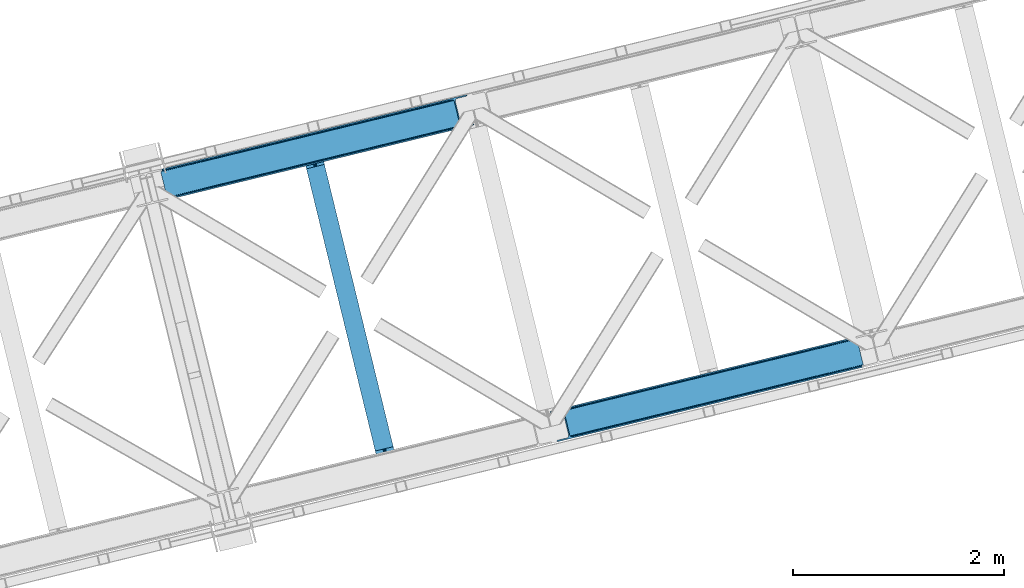
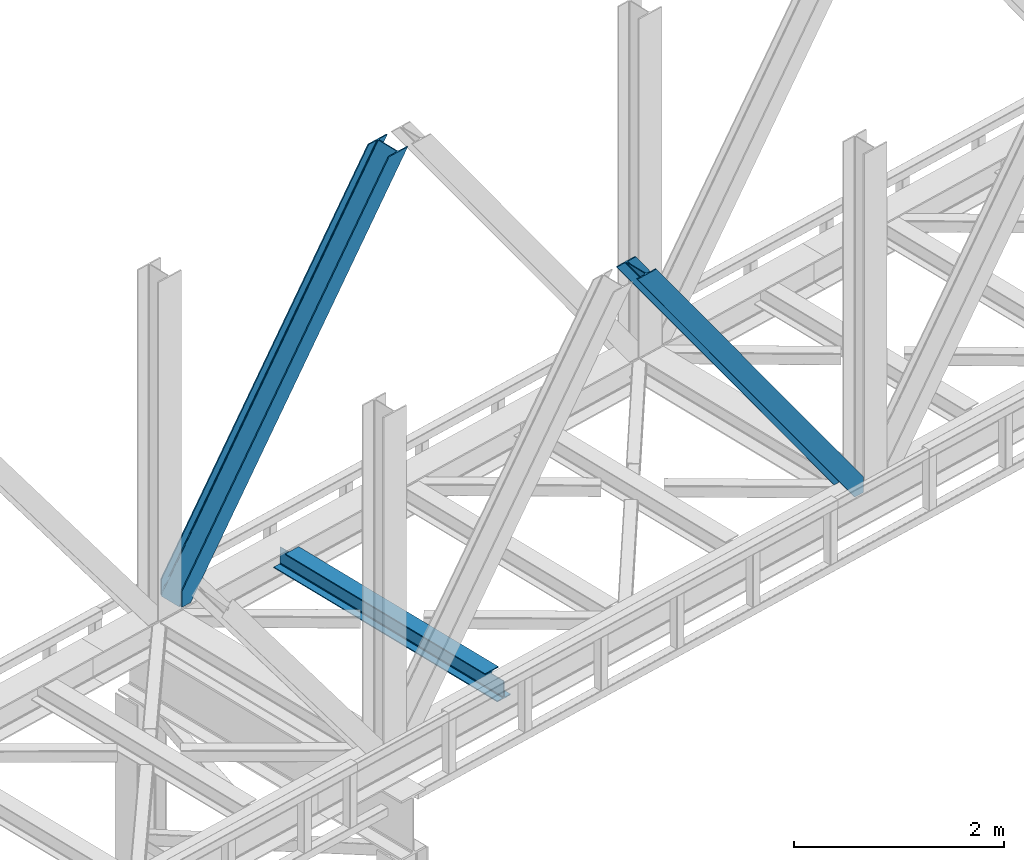
# One storey, part 59 of 92: 2 members, 1 beam.
"""IFC4 building model written with IfcOpenShell, lengths in millimetres."""

from ifc_helpers import new_model, entity, si_unit, converted_unit, derived_unit, direction, frame, origin, place, context, subcontext, project, spatial, triangles, polygons, material, type_object, element, save


model = new_model("IFC4")

# Units and contexts
model_context = context("Model", 3, precision=0.01, world=origin(), true_north=direction((6.12303176911189e-17, 1.0)))
plan_context = context("Plan", 3, precision=0.01, world=origin(), true_north=direction((6.12303176911189e-17, 1.0)))
body_context = subcontext(model_context, "Body", "Model", "MODEL_VIEW")
ifc_project = project(units=[si_unit("LENGTHUNIT", "METRE", prefix="MILLI"), si_unit("AREAUNIT", "SQUARE_METRE"), si_unit("VOLUMEUNIT", "CUBIC_METRE"), converted_unit("PLANEANGLEUNIT", "DEGREE", entity("IfcRatioMeasure", 0.0174532925199433), si_unit("PLANEANGLEUNIT", "RADIAN"), dimensions=[0, 0, 0, 0, 0, 0, 0]), si_unit("MASSUNIT", "GRAM", prefix="KILO"), derived_unit("MASSDENSITYUNIT", [(si_unit("MASSUNIT", "GRAM", prefix="KILO"), 1), (si_unit("LENGTHUNIT", "METRE"), -3)]), derived_unit("MOMENTOFINERTIAUNIT", [(si_unit("LENGTHUNIT", "METRE"), 4)]), si_unit("TIMEUNIT", "SECOND"), si_unit("FREQUENCYUNIT", "HERTZ"), si_unit("THERMODYNAMICTEMPERATUREUNIT", "DEGREE_CELSIUS"), derived_unit("THERMALTRANSMITTANCEUNIT", [(si_unit("MASSUNIT", "GRAM", prefix="KILO"), 1), (si_unit("THERMODYNAMICTEMPERATUREUNIT", "KELVIN"), -1), (si_unit("TIMEUNIT", "SECOND"), -3)]), derived_unit("VOLUMETRICFLOWRATEUNIT", [(si_unit("LENGTHUNIT", "METRE"), 3), (si_unit("TIMEUNIT", "SECOND"), -1)]), derived_unit("MASSFLOWRATEUNIT", [(si_unit("MASSUNIT", "GRAM", prefix="KILO"), 1), (si_unit("TIMEUNIT", "SECOND"), -1)]), derived_unit("ROTATIONALFREQUENCYUNIT", [(si_unit("TIMEUNIT", "SECOND"), -1)]), si_unit("ELECTRICCURRENTUNIT", "AMPERE"), si_unit("ELECTRICVOLTAGEUNIT", "VOLT"), si_unit("POWERUNIT", "WATT"), si_unit("FORCEUNIT", "NEWTON", prefix="KILO"), si_unit("ILLUMINANCEUNIT", "LUX"), si_unit("LUMINOUSFLUXUNIT", "LUMEN"), si_unit("LUMINOUSINTENSITYUNIT", "CANDELA"), derived_unit("USERDEFINED", [(si_unit("MASSUNIT", "GRAM", prefix="KILO"), -1), (si_unit("LENGTHUNIT", "METRE"), -2), (si_unit("TIMEUNIT", "SECOND"), 3), (si_unit("LUMINOUSFLUXUNIT", "LUMEN"), 1)]), derived_unit("LINEARVELOCITYUNIT", [(si_unit("LENGTHUNIT", "METRE"), 1), (si_unit("TIMEUNIT", "SECOND"), -1)]), si_unit("PRESSUREUNIT", "PASCAL"), derived_unit("USERDEFINED", [(si_unit("LENGTHUNIT", "METRE"), -2), (si_unit("MASSUNIT", "GRAM", prefix="KILO"), 1), (si_unit("TIMEUNIT", "SECOND"), -2)]), derived_unit("LINEARFORCEUNIT", [(si_unit("MASSUNIT", "GRAM", prefix="KILO"), 1), (si_unit("LENGTHUNIT", "METRE"), 1), (si_unit("TIMEUNIT", "SECOND"), -2), (si_unit("LENGTHUNIT", "METRE"), -1)]), derived_unit("PLANARFORCEUNIT", [(si_unit("MASSUNIT", "GRAM", prefix="KILO"), 1), (si_unit("LENGTHUNIT", "METRE"), 1), (si_unit("TIMEUNIT", "SECOND"), -2), (si_unit("LENGTHUNIT", "METRE"), -2)])], contexts=[model_context, plan_context])

# Site, building, storey
site_placement = place(None, origin())
site = spatial("IfcSite", under=ifc_project, at=site_placement, CompositionType="ELEMENT")
building_placement = place(site_placement, origin())
building = spatial("IfcBuilding", under=site, at=building_placement, CompositionType="ELEMENT")
storey_placement = place(building_placement, frame((0.0, 0.0, 15900.0)))
storey = spatial("IfcBuildingStorey", under=building, at=storey_placement, Name="05", CompositionType="ELEMENT", Elevation=15900.0)

# Beam
ifc_material = material(Name="Metal painted (White)")
beam_type = type_object("IfcBeamType", PredefinedType="BEAM")
beam_placement = place(storey_placement, frame((-28709.26, 10788.0, 3441.0)))
element("IfcBeam", 1, at=beam_placement, inside=storey, type_object=beam_type, material=ifc_material, ObjectType="Steel Beam", PredefinedType="BEAM", context=body_context, shape_type="Tessellation", body=[
    polygons([(898.853911352528, 41.4445662733125, 11.000000000004), (898.853911352528, 41.4445662733125, 2.16573425859679e-12), (170.021610174761, 3031.3960252037, 2.16573425859679e-12), (170.021610174761, 3031.3960252037, 11.000000000004), (832.788371398907, 25.3403919499678, 11.000000000004), (103.956070221144, 3015.29185088036, 11.000000000004), (826.839621377614, 23.8903211957417, 12.2179274798217), (98.0073201998513, 3013.84178012613, 12.2179274798217), (821.796514621501, 22.6610105689216, 15.6862915010192), (92.964213443734, 3012.61246949931, 15.6862915010192), (818.42681841833, 21.839611468714, 20.8770650821657), (89.5945172405668, 3011.7910703991, 20.8770650821657), (817.243538468644, 21.5511744621227, 27.0000000000047), (88.4112372908809, 3011.50263339251, 27.0000000000047), (81.6103728838888, 3009.84485074158, 27.0000000000047), (81.6103728838888, 3009.84485074158, 203.000000000006), (88.4112372908809, 3011.50263339251, 203.000000000006), (0.0, 2989.95145893039, 2.16573425859679e-12), (0.0, 2989.95145893039, 10.9999999999997), (66.0655399536216, 3006.05563325373, 11.000000000004), (72.014289974914, 3007.50570400796, 12.2179274798217), (77.057396731027, 3008.73501463478, 15.6862915010192), (80.4270929342029, 3009.55641373498, 20.8770650821657), (817.243538468644, 21.5511744621227, 203.000000000006), (810.442674061652, 19.8933918111876, 203.000000000006), (810.442674061652, 19.8933918111919, 27.0000000000047), (809.259394111966, 19.6049548045984, 20.8770650821657), (805.889697908794, 18.7835557043909, 15.6862915010192), (800.846591152681, 17.5542450775685, 12.2179274798217), (794.897841131389, 16.1041743233447, 11.000000000004), (728.832301177767, 0.0, 10.9999999999997), (728.832301177763, 0.0, 2.16573425859679e-12), (777.543778045854, 184.415062601696, 203.069791966819), (125.8889665066, 2857.75452019162, 203.000000000006), (126.111847295751, 2856.8401777572, 203.617301946336), (126.124761540274, 2856.7871977843, 217.000003693143), (777.398574796925, 185.010597404072, 217.000003676718), (777.399445404814, 185.007025963197, 204.00000679514), (770.833476881408, 182.385463974445, 203.006342981529), (770.610629219866, 183.299815969776, 203.617301946336), (770.597714975342, 183.352795942669, 217.000003693143), (119.323901718691, 2855.1293963229, 217.000003676718), (119.323031110802, 2855.13296776378, 204.00000679514), (119.178731521743, 2855.72494066435, 203.076120467494), (119.088102099608, 2856.09673754069, 203.000000000006), (778.58205952096, 185.298194377518, 223.122939328039), (781.951055929627, 186.122464201395, 228.313710402595), (786.993691333646, 187.353708426699, 231.782072735464), (792.942270204363, 188.804481281383, 232.999999602236), (859.007721069886, 204.909021065317, 232.999999283132), (859.006247733445, 204.91506504219, 243.999994005812), (688.984866829519, 163.4695582453, 243.999994827032), (688.986340165957, 163.463514268427, 233.000000104353), (755.05179103148, 179.568054052361, 232.999999785253), (761.000696159814, 181.017488520584, 231.782072861016), (766.044260666945, 182.244921343721, 228.313710479427), (769.41464757669, 183.06348700115, 223.12293937232), (118.140416994664, 2854.84179934945, 223.122939328039), (114.771420585985, 2854.01752952558, 228.313710402595), (109.728785181961, 2852.78628530027, 231.782072735464), (103.780206311253, 2851.33551244559, 232.999999602236), (37.7147554457299, 2835.23097266166, 232.999999283128), (37.7162287821674, 2835.22492868478, 243.999994005812), (207.737609686093, 2876.67043548167, 243.999994827032), (207.736136349655, 2876.67647945855, 233.000000104357), (141.670685484123, 2860.57193967461, 232.999999785253), (135.721780355798, 2859.12250520639, 231.782072861012), (130.678215848671, 2857.89507238325, 228.313710479427), (127.307828938926, 2857.07650672582, 223.12293937232)], [[[1, 2, 3, 4]], [[5, 1, 4, 6]], [[7, 5, 6, 8]], [[9, 7, 8, 10]], [[11, 9, 10, 12]], [[13, 11, 12, 14]], [[15, 16, 17, 14, 12, 10, 8, 6, 4, 3, 18, 19, 20, 21, 22, 23]], [[13, 24, 25, 26, 27, 28, 29, 30, 31, 32, 2, 1, 5, 7, 9, 11]], [[2, 32, 18, 3]], [[32, 31, 19, 18]], [[31, 30, 20, 19]], [[27, 26, 15, 23]], [[28, 27, 23, 22]], [[29, 28, 22, 21]], [[30, 29, 21, 20]], [[33, 24, 13, 14, 17, 34, 35, 36, 37, 38]], [[25, 39, 40, 41, 42, 43, 44, 16, 15, 26]], [[39, 25, 24, 33]], [[45, 34, 17, 16]], [[41, 40, 38, 37, 46, 47, 48, 49, 50, 51, 52, 53, 54, 55, 56, 57]], [[42, 58, 59, 60, 61, 62, 63, 64, 65, 66, 67, 68, 69, 36, 35, 43]], [[46, 37, 36, 69]], [[47, 46, 69, 68]], [[48, 47, 68, 67]], [[49, 48, 67, 66]], [[50, 49, 66, 65]], [[51, 50, 65, 64]], [[52, 51, 64, 63]], [[53, 52, 63, 62]], [[54, 53, 62, 61]], [[55, 54, 61, 60]], [[56, 55, 60, 59]], [[57, 56, 59, 58]], [[41, 57, 58, 42]]], closed=False),
])

# Members
member_type_1 = type_object("IfcMemberType", PredefinedType="BRACE")
member_1_placement = place(storey_placement, frame((-26366.37, 11039.71, 3695.0)))
element("IfcMember", 2, at=member_1_placement, inside=storey, type_object=member_type_1, ObjectType="Steel Vertical Brace", PredefinedType="BRACE", context=body_context, shape_type="Tessellation", body=[
    triangles([(2966.89099731445, 730.998403930664, 0.80925292968459), (2967.55142211914, 730.014743041993, 1.10690917968532), (2966.07941894531, 729.656625366211, 0.0), (2964.18418579101, 737.428244018554, 0.0), (2962.43312988281, 728.767144775391, 8.31577148437282), (2962.43312988281, 728.767144775391, 0.0), (2505.85634765625, 612.605630493164, 658.855133056641), (2511.35833740234, 609.931375122071, 662.301434326171), (2954.04061889648, 717.839904785156, 38.6743835449197), (2954.16851806641, 719.76304321289, 32.1678039550752), (2501.41243286133, 617.533236694337, 656.552947998047), (2958.54266967773, 726.956790161134, 14.8293273925774), (2955.07311401367, 722.241961669923, 26.1867736816384), (2955.63819580078, 723.795355224609, 22.4381652832017), (655.164660644532, 156.053265380859, 3289.34108276367), (649.437103271484, 156.067218017579, 3285.27854003906), (213.879968261717, 48.4854125976563, 3911.00081176758), (205.268865966795, 47.7970825195316, 3911.00081176758), (643.932788085938, 158.742636108398, 3281.83223876953), (197.318188476562, 49.8748626708984, 3911.00081176758), (639.488873291015, 163.669079589843, 3279.53005371094), (191.239489746094, 54.4036560058594, 3911.00081176758), (636.782061767579, 170.100082397461, 3278.7231262207), (187.958294677734, 60.6939697265625, 3911.00081176758), (2954.15921630859, 716.45859375, 50.6410949707024), (2517.08822021484, 609.917422485352, 666.36397705078), (2051.60733032227, 496.451092529296, 1322.10767211914), (2045.87977294922, 496.465045166016, 1318.04512939453), (1586.12644042969, 382.985925292969, 1977.85369262695), (1580.39888305664, 382.99871520996, 1973.78882446289), (1120.64555053711, 269.519595336915, 2633.59738769531), (1114.91799316406, 269.533547973633, 2629.53251953125), (2040.37545776367, 499.13930053711, 1314.598828125), (1574.89456787109, 385.674133300781, 1970.34484863281), (1109.41367797851, 272.207803344727, 2626.08854370117), (2035.93154296875, 504.066906738281, 1312.29896850586), (1570.45065307617, 390.600576782226, 1968.04266357422), (1104.96976318359, 277.135409545899, 2623.78635864258), (2498.70562133789, 623.963076782227, 655.74602050781), (2033.22473144531, 510.496746826171, 1311.48971557617), (1567.74384155273, 397.031579589844, 1967.23341064453), (1102.26295166016, 283.56524963379, 2622.97710571289), (2909.00383300781, 963.80047302246, 0.0), (2443.52526855469, 850.334143066406, 655.74602050781), (1978.04437866211, 736.868975830079, 1311.48971557617), (1512.56348876953, 623.402645874023, 1967.23341064453), (1047.08259887695, 509.937478637696, 2622.97710571289), (581.601708984374, 396.471148681641, 3278.7231262207), (132.777941894532, 287.066198730468, 3911.00081176758), (307.432397460936, 71.2898345947269, 3911.00081176758), (2954.15921630859, 716.45859375, 182.433050537107), (2954.3522277832, 715.474932861329, 0.0), (2954.16851806641, 719.76304321289, 0.0), (2954.3522277832, 715.474932861329, 182.495837402341), (2955.63819580078, 723.795355224609, 0.0), (2958.54266967773, 726.956790161134, 0.0), (2957.19391479492, 703.816342163085, 182.495837402341), (310.511279296876, 58.6603729248054, 3911.00081176758), (2957.19391479492, 703.816342163085, 0.0), (2846.08906860352, 676.734274291992, 0.0), (69.8631774902351, 0.0, 3911.00081176758), (2843.01018676758, 689.363735961913, 0.0), (66.7842956542954, 12.6294616699215, 3911.00081176758), (160.334399414063, 35.4338836669922, 3911.00081176758), (2936.5626159668, 712.168157958984, 0.0), (2953.95690307617, 734.935372924805, 0.0), (2953.940625, 727.841619873047, 0.0), (177.731011962889, 58.2010986328132, 3911.00081176758), (177.714733886718, 51.1073455810547, 3911.00081176758), (2950.6268737793, 721.023431396485, 0.0), (174.400982666015, 44.2891571044929, 3911.00081176758), (2944.5249206543, 715.519116210937, 0.0), (168.299029541016, 38.7848419189449, 3911.00081176758), (2898.77655029297, 961.307601928711, 0.0), (122.550659179688, 284.573327636719, 3911.00081176758), (2872.85720214844, 973.516159057617, 0.0), (2881.46830444336, 974.204489135742, 0.0), (105.242413330077, 297.47021484375, 3911.00081176758), (96.6289855957039, 296.780722045898, 3911.00081176758), (2889.41898193359, 972.126708984375, 0.0), (113.19309082031, 295.392434692383, 3911.00081176758), (2895.49535522461, 967.597915649414, 0.0), (119.269464111327, 290.863641357422, 3911.00081176758), (3.07888183593604, 273.977462768555, 3911.00081176758), (2779.30477294922, 950.711737060547, 0.0), (2776.22589111328, 963.341198730468, 0.0), (0.0, 286.606924438476, 3911.00081176758), (142.209924316405, 306.482455444337, 3911.00081176758), (150.174554443358, 309.833413696289, 3911.00081176758), (136.107971191406, 300.978140258789, 3911.00081176758), (132.796545410154, 294.159951782227, 3911.00081176758), (240.648101806641, 345.267297363282, 3911.00081176758), (243.726983642577, 332.63783569336, 3911.00081176758), (2887.33073730469, 990.424429321289, 182.495837402341), (2887.33073730469, 990.424429321289, 0.0), (2890.45380249023, 977.805432128906, 182.433050537107), (2890.17242431641, 978.765838623047, 182.495837402341), (1522.42102661133, 644.332763671875, 1977.85369262695), (591.459246826173, 417.401266479492, 3289.34108276367), (1056.94013671875, 530.867596435546, 2633.59738769531), (1987.90191650391, 757.799093627929, 1322.10767211914), (2453.38280639648, 871.264260864258, 666.36397705078), (2890.45380249023, 977.805432128906, 50.6410949707024), (2890.17242431641, 978.765838623047, 0.0), (2890.98400268555, 976.524114990234, 38.6743835449197), (2892.14672241211, 974.998626708984, 33.1630920410134), (2891.98161621094, 974.874215698243, 0.0), (2893.56524047851, 973.137112426757, 26.4425720214822), (2895.14421386719, 971.972067260742, 22.4381652832017), (2903.46463623047, 970.68377380371, 8.31577148437282), (2903.46463623047, 970.68377380371, 0.0), (2899.17652587891, 970.500064086915, 0.0), (2899.17652587891, 970.500064086915, 14.8293273925774), (2895.14421386719, 971.972067260742, 0.0), (2907.11092529297, 971.573254394531, 0.0), (2444.64613037109, 863.708908081055, 658.855133056641), (2442.96716308594, 857.289532470702, 656.552947998047), (2908.44805297851, 970.754699707031, 0.80925292968459), (2908.58060302734, 971.931372070312, 1.10690917968532), (581.045928955078, 403.425375366211, 3279.53005371094), (582.724896240234, 409.845913696288, 3281.83223876953), (586.380487060545, 414.752590942382, 3285.27854003906), (2448.3017211914, 868.615585327148, 662.301434326171), (1977.48859863281, 743.823202514648, 1312.29896850586), (1512.00770874024, 630.356872558594, 1968.04266357422), (1046.52681884765, 516.891705322265, 2623.78635864258), (1979.16524047852, 750.242578125, 1314.598828125), (1513.68435058594, 636.777410888672, 1970.34484863281), (1048.20578613281, 523.311080932617, 2626.08854370117), (1982.82083129883, 755.15041809082, 1318.04512939453), (1517.33994140625, 641.684088134765, 1973.78882446289), (1051.86137695313, 528.218920898438, 2629.53251953125)], [[1, 2, 3], [3, 4, 1], [2, 5, 6], [6, 3, 2], [7, 8, 9], [9, 10, 7], [11, 12, 5], [5, 1, 11], [11, 7, 13], [13, 14, 11], [14, 12, 11], [15, 16, 17], [18, 17, 16], [16, 19, 18], [20, 18, 19], [19, 21, 20], [22, 20, 21], [21, 23, 22], [24, 22, 23], [5, 2, 1], [10, 13, 7], [25, 9, 8], [8, 26, 25], [26, 8, 27], [28, 27, 8], [27, 28, 29], [30, 29, 28], [29, 30, 31], [32, 31, 30], [31, 32, 15], [16, 15, 32], [8, 7, 33], [33, 28, 8], [28, 33, 34], [34, 30, 28], [30, 34, 35], [35, 32, 30], [32, 35, 16], [19, 16, 35], [7, 11, 36], [36, 33, 7], [33, 36, 37], [37, 34, 33], [34, 37, 38], [38, 35, 34], [35, 38, 21], [21, 19, 35], [1, 4, 11], [39, 11, 4], [11, 39, 36], [40, 36, 39], [36, 40, 37], [41, 37, 40], [37, 41, 42], [42, 38, 37], [38, 42, 23], [23, 21, 38], [4, 43, 44], [45, 39, 44], [41, 40, 45], [41, 45, 46], [44, 39, 4], [45, 40, 39], [42, 41, 46], [46, 47, 42], [47, 48, 23], [49, 24, 48], [47, 23, 42], [48, 24, 23], [50, 51, 29], [29, 31, 50], [31, 15, 50], [17, 50, 15], [27, 29, 51], [51, 25, 26], [26, 27, 51], [52, 9, 25], [52, 53, 10], [10, 9, 52], [25, 51, 54], [54, 52, 25], [14, 53, 55], [53, 14, 13], [10, 53, 13], [56, 12, 55], [14, 55, 12], [6, 5, 56], [12, 56, 5], [57, 54, 58], [54, 51, 50], [50, 58, 54], [57, 59, 52], [52, 54, 57], [58, 60, 57], [58, 61, 60], [60, 59, 57], [62, 60, 63], [61, 63, 60], [63, 64, 62], [65, 62, 64], [66, 67, 68], [69, 68, 67], [67, 70, 69], [71, 69, 70], [70, 72, 71], [73, 71, 72], [72, 65, 73], [64, 73, 65], [74, 66, 75], [68, 75, 66], [76, 77, 78], [78, 79, 76], [77, 80, 81], [81, 78, 77], [80, 82, 83], [83, 81, 80], [82, 74, 75], [75, 83, 82], [79, 84, 85], [85, 76, 79], [86, 85, 87], [84, 87, 85], [75, 68, 49], [71, 73, 18], [64, 61, 17], [63, 61, 64], [73, 64, 17], [68, 69, 22], [69, 71, 20], [81, 88, 78], [87, 79, 89], [79, 78, 89], [87, 84, 79], [81, 83, 90], [83, 75, 91], [49, 68, 24], [17, 18, 73], [22, 69, 20], [18, 20, 71], [22, 24, 68], [58, 17, 61], [58, 50, 17], [89, 78, 88], [90, 83, 91], [49, 91, 75], [90, 88, 81], [89, 92, 87], [92, 89, 93], [92, 86, 87], [86, 92, 94], [95, 86, 94], [96, 97, 93], [97, 94, 92], [92, 93, 97], [98, 96, 93], [93, 99, 100], [99, 93, 89], [100, 98, 93], [96, 98, 101], [101, 102, 96], [103, 96, 102], [97, 104, 94], [95, 94, 104], [104, 105, 106], [96, 103, 97], [104, 97, 103], [103, 105, 104], [107, 108, 109], [107, 106, 108], [110, 111, 112], [112, 113, 110], [113, 112, 114], [114, 109, 113], [109, 114, 107], [106, 107, 104], [53, 70, 55], [76, 86, 95], [85, 86, 76], [77, 76, 95], [104, 80, 77], [77, 95, 104], [104, 107, 80], [60, 65, 59], [52, 72, 70], [65, 72, 59], [60, 62, 65], [70, 53, 52], [52, 59, 72], [43, 66, 74], [82, 112, 74], [80, 114, 82], [80, 107, 114], [82, 114, 112], [111, 43, 74], [112, 111, 74], [43, 111, 115], [4, 66, 43], [56, 66, 6], [55, 70, 67], [67, 66, 56], [56, 55, 67], [4, 6, 66], [3, 6, 4], [116, 113, 109], [117, 118, 113], [113, 116, 117], [109, 108, 116], [118, 119, 110], [110, 113, 118], [48, 120, 91], [91, 49, 48], [120, 121, 90], [90, 91, 120], [121, 122, 88], [88, 90, 121], [122, 99, 89], [89, 88, 122], [105, 103, 123], [102, 123, 103], [106, 116, 108], [116, 106, 105], [123, 116, 105], [43, 118, 117], [117, 44, 43], [44, 117, 124], [124, 45, 44], [45, 124, 125], [125, 46, 45], [46, 125, 47], [126, 47, 125], [47, 126, 48], [120, 48, 126], [117, 116, 124], [127, 124, 116], [124, 127, 125], [128, 125, 127], [125, 128, 126], [129, 126, 128], [126, 129, 120], [121, 120, 129], [116, 123, 127], [130, 127, 123], [127, 130, 128], [131, 128, 130], [128, 131, 129], [132, 129, 131], [129, 132, 122], [122, 121, 129], [123, 102, 101], [101, 130, 123], [130, 101, 98], [98, 131, 130], [131, 98, 100], [100, 132, 131], [132, 100, 99], [99, 122, 132], [110, 119, 111], [115, 111, 119], [119, 118, 115], [43, 115, 118]]),
])
member_type_2 = type_object("IfcMemberType", PredefinedType="BRACE")
member_2_placement = place(storey_placement, frame((-30052.87, 13334.38, 3695.0)))
element("IfcMember", 3, at=member_2_placement, inside=storey, type_object=member_type_2, ObjectType="Steel Vertical Brace", PredefinedType="BRACE", context=body_context, shape_type="Tessellation", body=[
    triangles([(58.547589111331, 26.625119018554, 0.0), (60.4428222656279, 18.8523376464836, 0.0), (59.1033691406265, 19.6697296142574, 0.80925292968459), (58.9684936523445, 18.4930572509766, 1.10690917968532), (64.0867858886741, 19.7406555175785, 8.31577148437282), (64.0867858886741, 19.7406555175785, 0.0), (522.905291748048, 126.716683959961, 658.855133056641), (68.3748962402351, 19.9243652343739, 14.8293273925774), (72.407208251956, 18.4523620605469, 22.4381652832017), (524.584259033203, 133.136059570312, 656.552947998047), (73.9861816406265, 17.2873168945316, 26.4425720214822), (2834.75487670899, 696.264477539062, 3911.00081176758), (2834.77348022461, 703.359393310546, 3911.00081176758), (2385.94971313477, 593.953280639647, 3278.7231262207), (2386.50781860352, 586.999053955078, 3279.53005371094), (2831.44345092774, 689.447451782225, 3911.00081176758), (2384.82885131836, 580.579678344726, 3281.83223876953), (2825.34149780274, 683.943136596679, 3911.00081176758), (2381.1709350586, 575.671838378907, 3285.27854003906), (2817.37686767578, 680.591015624999, 3911.00081176758), (2376.09217529297, 573.024325561522, 3289.34108276367), (514.170941162112, 119.160168457031, 666.36397705078), (519.247375488281, 121.80884399414, 662.301434326171), (77.0976196289084, 12.6201599121086, 50.6410949707024), (76.5650939941406, 13.9003143310547, 38.6743835449197), (75.4046997070327, 15.4258026123043, 33.1630920410134), (524.028479003908, 140.090286254883, 655.74602050781), (990.065148925783, 246.601226806641, 1312.29896850586), (989.509368896488, 253.556616210937, 1311.48971557617), (1455.54603881836, 360.067556762695, 1968.04266357422), (1454.99025878906, 367.021783447266, 1967.23341064453), (1921.02692871094, 473.533886718749, 2623.78635864258), (1920.47114868164, 480.48811340332, 2622.97710571289), (988.386181640628, 240.181851196288, 1314.598828125), (1453.8670715332, 353.648181152343, 1970.34484863281), (1919.34796142578, 467.113348388672, 2626.08854370117), (984.728265380862, 235.274011230469, 1318.04512939453), (1450.20915527344, 348.740341186523, 1973.78882446289), (1915.69004516602, 462.20550842285, 2629.53251953125), (979.651831054689, 232.626498413085, 1322.10767211914), (1445.13272094727, 346.092828369141, 1977.85369262695), (1910.61361083985, 459.557995605468, 2633.59738769531), (77.0976196289084, 12.6201599121086, 182.433050537107), (2723.82443847656, 657.786593627929, 3911.00081176758), (75.5674804687515, 15.5502136230461, 0.0), (77.381323242189, 11.6585906982418, 0.0), (77.381323242189, 11.6585906982418, 182.495837402341), (68.3748962402351, 19.9243652343739, 0.0), (72.407208251956, 18.4523620605469, 0.0), (2726.9033203125, 645.157131958007, 3911.00081176758), (80.223010253907, 0.0, 182.495837402341), (80.223010253907, 0.0, 0.0), (191.327856445314, 27.0832305908207, 0.0), (2967.5537475586, 703.817504882813, 3911.00081176758), (1399.80990600586, 593.394012451172, 1967.23341064453), (2779.59312744141, 929.730459594726, 3911.00081176758), (2330.76936035157, 820.325509643555, 3278.7231262207), (1865.29079589844, 706.859179687499, 2622.97710571289), (934.329016113283, 479.927682495118, 1311.48971557617), (468.848126220706, 366.462515258789, 655.74602050781), (3.36723632812573, 252.996185302734, 0.0), (2964.47486572266, 716.448129272461, 3911.00081176758), (188.248974609378, 39.7138549804677, 0.0), (2870.92243652344, 693.643707275391, 3911.00081176758), (94.6965454101592, 16.9094329833988, 0.0), (2862.31133422852, 692.954214477539, 3911.00081176758), (86.083117675782, 16.2199401855469, 0.0), (2854.35833129883, 695.031994628906, 3911.00081176758), (78.1324401855491, 18.2977203369137, 0.0), (2848.27963256836, 699.560787963866, 3911.00081176758), (72.0537414550781, 22.8265136718746, 0.0), (2845.00076293946, 705.852264404297, 3911.00081176758), (68.7725463867209, 29.1168273925778, 0.0), (2789.82041015625, 932.223330688475, 3911.00081176758), (13.5921936035156, 255.489056396484, 0.0), (2789.83668823242, 939.318246459961, 3911.00081176758), (13.6107971191414, 262.582809448242, 0.0), (2793.14811401367, 946.135272216796, 3911.00081176758), (16.9222229003935, 269.400997924804, 0.0), (2799.25239257813, 951.639587402344, 3911.00081176758), (23.0241760253921, 274.904150390625, 0.0), (2807.21469726563, 954.990545654297, 3911.00081176758), (30.9888061523452, 278.256271362305, 0.0), (2900.76712646485, 977.794967651367, 3911.00081176758), (124.541235351564, 301.060693359375, 0.0), (2897.68824462891, 990.425592041016, 3911.00081176758), (121.462353515628, 313.691317749022, 0.0), (2770.23555908203, 940.54956665039, 3911.00081176758), (2762.2848815918, 942.628509521484, 3911.00081176758), (2657.04014282227, 931.765219116211, 3911.00081176758), (2753.67145385742, 941.939016723632, 3911.00081176758), (2660.1190246582, 919.134594726562, 3911.00081176758), (2776.31193237305, 936.020773315429, 3911.00081176758), (10.3575073242209, 286.608087158203, 182.495837402341), (10.3575073242209, 286.608087158203, 0.0), (13.2015197753935, 274.94949645996, 182.495837402341), (13.3922058105491, 273.966998291015, 182.433050537107), (1381.42498168946, 607.439666748047, 1977.85369262695), (1846.90587158203, 720.905996704101, 2633.59738769531), (2312.38676147461, 834.37116394043, 3289.34108276367), (915.944091796879, 493.973336791993, 1322.10767211914), (13.3922058105491, 273.966998291015, 50.6410949707024), (450.465527343753, 380.508169555664, 666.36397705078), (13.2015197753935, 274.94949645996, 0.0), (13.5084777832053, 272.584524536132, 38.6743835449197), (13.3829040527344, 270.661386108399, 0.0), (13.3829040527344, 270.661386108399, 32.1678039550752), (12.4783081054702, 268.183630371093, 26.1867736816384), (11.9109008789092, 266.62907409668, 22.4381652832017), (11.9109008789092, 266.62907409668, 0.0), (9.00875244140843, 263.467639160155, 14.8293273925774), (9.00875244140843, 263.467639160155, 0.0), (5.115966796875, 261.657284545898, 8.31577148437282), (5.115966796875, 261.657284545898, 0.0), (1.47200317382885, 260.768966674805, 0.0), (461.697399902347, 377.819961547852, 658.855133056641), (456.190759277346, 380.493054199218, 662.301434326171), (466.141314697266, 372.892355346679, 656.552947998047), (0.660424804689683, 259.42718811035, 0.80925292968459), (0.0, 260.409686279296, 1.10690917968532), (2318.11431884766, 834.35721130371, 3285.27854003906), (2323.61863403321, 831.682955932616, 3281.83223876953), (2328.06254882813, 826.755349731446, 3279.53005371094), (921.671649169923, 493.959384155272, 1318.04512939453), (1387.1525390625, 607.424551391601, 1973.78882446289), (1852.63342895508, 720.890881347656, 2629.53251953125), (927.178289794923, 491.285128784179, 1314.598828125), (1392.6591796875, 604.751458740235, 1970.34484863281), (1858.13774414063, 718.216625976562, 2626.08854370117), (931.622204589847, 486.358685302734, 1312.29896850586), (1397.10309448242, 599.823852539063, 1968.04266357422), (1862.583984375, 713.290182495117, 2623.78635864258)], [[1, 2, 3], [4, 3, 2], [5, 4, 6], [2, 6, 4], [7, 8, 9], [10, 3, 8], [8, 7, 10], [9, 11, 7], [3, 4, 5], [5, 8, 3], [12, 13, 14], [14, 15, 12], [16, 12, 15], [15, 17, 16], [18, 16, 17], [17, 19, 18], [20, 18, 19], [19, 21, 20], [22, 23, 24], [25, 24, 23], [25, 7, 26], [25, 23, 7], [11, 26, 7], [10, 27, 1], [1, 3, 10], [28, 29, 27], [27, 10, 28], [30, 31, 28], [29, 28, 31], [32, 33, 31], [31, 30, 32], [15, 14, 33], [33, 32, 15], [34, 28, 10], [10, 7, 34], [35, 30, 28], [28, 34, 35], [36, 32, 35], [30, 35, 32], [17, 15, 36], [32, 36, 15], [37, 34, 23], [7, 23, 34], [38, 35, 37], [34, 37, 35], [39, 36, 38], [35, 38, 36], [19, 17, 36], [36, 39, 19], [40, 37, 22], [23, 22, 37], [41, 38, 40], [37, 40, 38], [42, 39, 41], [38, 41, 39], [21, 19, 42], [39, 42, 19], [41, 43, 44], [44, 21, 42], [21, 44, 20], [42, 41, 44], [43, 41, 40], [40, 22, 43], [24, 43, 22], [45, 11, 9], [45, 26, 11], [46, 25, 26], [46, 47, 24], [43, 24, 47], [24, 25, 46], [26, 45, 46], [48, 8, 5], [5, 6, 48], [49, 9, 8], [8, 48, 49], [9, 49, 45], [47, 44, 43], [50, 47, 51], [47, 50, 44], [52, 51, 46], [47, 46, 51], [50, 53, 54], [53, 50, 51], [52, 53, 51], [33, 55, 31], [13, 56, 57], [58, 14, 57], [55, 33, 58], [57, 14, 13], [58, 33, 14], [31, 59, 29], [59, 60, 27], [59, 31, 55], [61, 1, 60], [59, 27, 29], [60, 1, 27], [62, 54, 53], [53, 63, 62], [64, 62, 63], [63, 65, 64], [66, 64, 65], [65, 67, 66], [68, 66, 67], [67, 69, 68], [70, 68, 69], [69, 71, 70], [72, 70, 71], [71, 73, 72], [74, 72, 75], [73, 75, 72], [76, 74, 77], [75, 77, 74], [78, 76, 79], [77, 79, 76], [80, 78, 81], [79, 81, 78], [82, 80, 83], [81, 83, 80], [84, 82, 85], [83, 85, 82], [86, 84, 85], [85, 87, 86], [56, 13, 74], [16, 18, 66], [20, 50, 54], [44, 50, 20], [18, 20, 64], [13, 12, 70], [12, 16, 68], [88, 80, 89], [90, 91, 86], [91, 89, 82], [90, 92, 91], [88, 93, 78], [93, 56, 76], [74, 13, 72], [64, 66, 18], [70, 12, 68], [66, 68, 16], [70, 72, 13], [54, 64, 20], [54, 62, 64], [82, 89, 80], [78, 93, 76], [74, 76, 56], [78, 80, 88], [82, 86, 91], [86, 82, 84], [90, 87, 94], [90, 86, 87], [87, 95, 94], [96, 90, 94], [92, 96, 97], [96, 92, 90], [92, 97, 98], [98, 99, 92], [99, 100, 92], [91, 92, 100], [101, 98, 97], [97, 102, 103], [103, 101, 97], [104, 96, 94], [94, 95, 104], [104, 105, 102], [104, 106, 107], [107, 105, 104], [96, 104, 102], [102, 97, 96], [108, 106, 109], [108, 107, 106], [110, 109, 106], [109, 110, 111], [112, 111, 110], [111, 112, 113], [114, 113, 112], [75, 73, 61], [114, 75, 61], [114, 112, 75], [114, 61, 115], [79, 77, 110], [77, 75, 112], [106, 79, 110], [110, 77, 112], [73, 1, 61], [6, 73, 48], [1, 6, 2], [1, 73, 6], [48, 71, 49], [49, 71, 69], [73, 71, 48], [45, 49, 69], [104, 81, 79], [79, 106, 104], [95, 81, 104], [83, 95, 87], [87, 85, 83], [83, 81, 95], [45, 69, 46], [52, 67, 65], [46, 69, 67], [52, 46, 67], [65, 53, 52], [53, 65, 63], [116, 117, 105], [105, 107, 116], [118, 111, 113], [113, 119, 118], [118, 116, 108], [108, 109, 118], [109, 111, 118], [113, 120, 119], [107, 108, 116], [117, 103, 102], [102, 105, 117], [89, 91, 121], [100, 121, 91], [88, 89, 122], [121, 122, 89], [93, 88, 123], [122, 123, 88], [56, 93, 57], [123, 57, 93], [124, 101, 103], [103, 117, 124], [125, 98, 101], [101, 124, 125], [126, 99, 98], [98, 125, 126], [121, 100, 126], [99, 126, 100], [127, 124, 116], [117, 116, 124], [128, 125, 124], [124, 127, 128], [129, 126, 128], [125, 128, 126], [122, 121, 129], [126, 129, 121], [130, 127, 118], [116, 118, 127], [131, 128, 130], [127, 130, 128], [132, 129, 128], [128, 131, 132], [123, 122, 129], [129, 132, 123], [60, 118, 61], [119, 61, 118], [59, 130, 60], [118, 60, 130], [55, 131, 130], [130, 59, 55], [58, 132, 55], [131, 55, 132], [57, 123, 58], [132, 58, 123], [120, 113, 114], [114, 115, 120], [115, 61, 119], [119, 120, 115]]),
])

save(model, "model.ifc")
